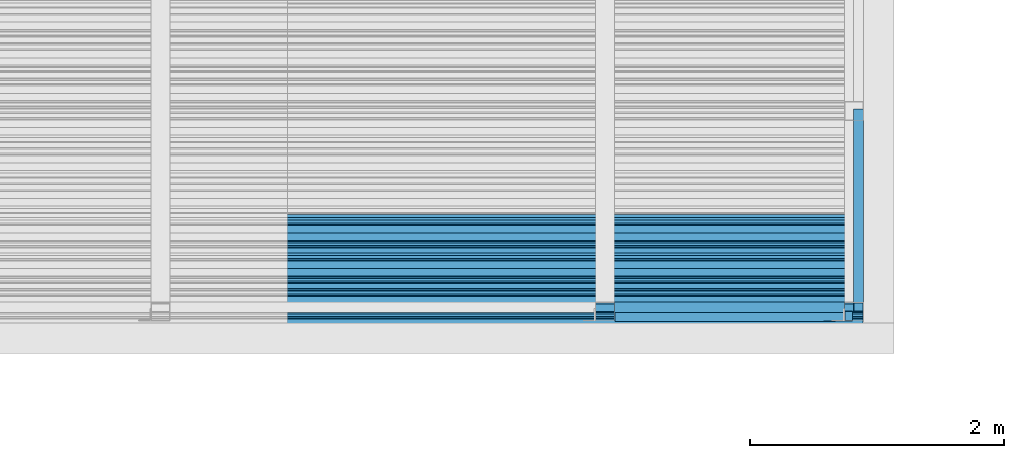
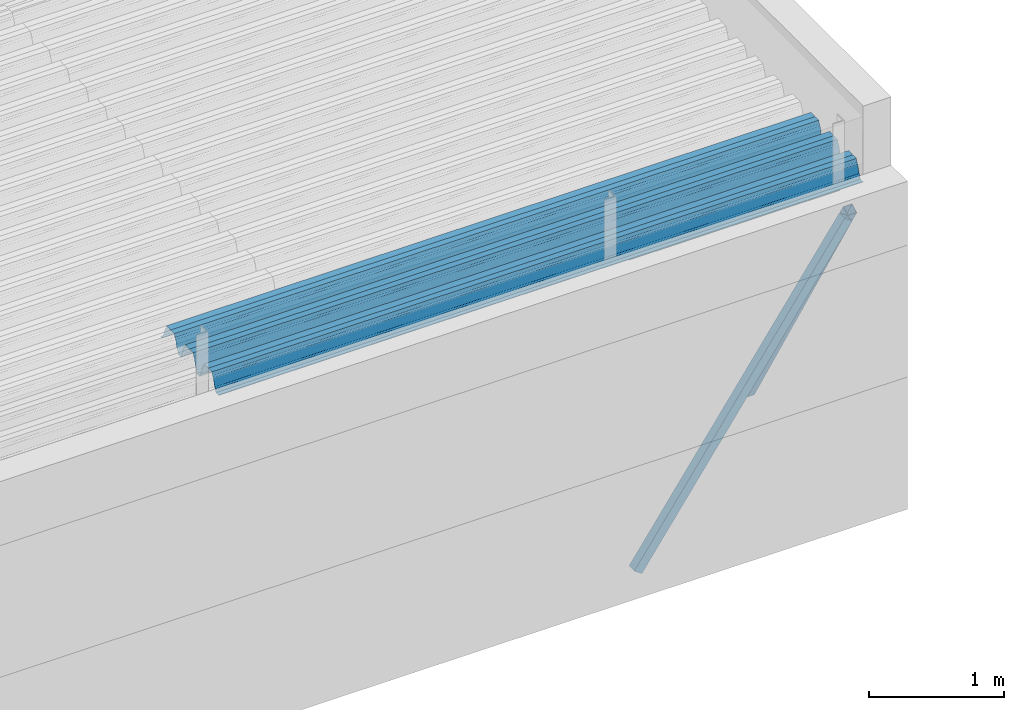
# One storey, part 21 of 153: 2 beams, 2 members, 4 elements without a shape of their own.
"""IFC2X3 building model written with IfcOpenShell, lengths in millimetres."""

from ifc_helpers import new_model, si_unit, frame, origin_with_axes, place, context, subcontext, project, spatial, faceted_brep, material, type_object, element, aggregate, save


model = new_model("IFC2X3")

# Units and contexts
model_context = context("Model", 3, precision=1e-05, world=origin_with_axes())
body_context = subcontext(model_context, "Body", "Model", "MODEL_VIEW")
ifc_project = project(units=[si_unit("LENGTHUNIT", "METRE", prefix="MILLI"), si_unit("AREAUNIT", "SQUARE_METRE"), si_unit("VOLUMEUNIT", "CUBIC_METRE"), si_unit("MASSUNIT", "GRAM", prefix="KILO"), si_unit("TIMEUNIT", "SECOND"), si_unit("PLANEANGLEUNIT", "RADIAN"), si_unit("SOLIDANGLEUNIT", "STERADIAN"), si_unit("THERMODYNAMICTEMPERATUREUNIT", "DEGREE_CELSIUS"), si_unit("LUMINOUSINTENSITYUNIT", "LUMEN")], contexts=[model_context])

# Site, building, storey
site_placement = place(None, origin_with_axes())
site = spatial("IfcSite", under=ifc_project, at=site_placement, CompositionType="ELEMENT")
building_placement = place(site_placement, origin_with_axes())
building = spatial("IfcBuilding", under=site, at=building_placement, CompositionType="ELEMENT")
storey_placement = place(building_placement, origin_with_axes())
storey = spatial("IfcBuildingStorey", under=building, at=storey_placement, Name="8", CompositionType="ELEMENT", Elevation=0.0)

# Assembly, beam
assembly_1_placement = place(storey_placement, origin_with_axes())
assembly_1 = element("IfcElementAssembly", 1, at=assembly_1_placement, inside=storey, Name="Steel Assembly", AssemblyPlace="NOTDEFINED", PredefinedType="RIGID_FRAME")
ifc_material = material(Name="STEEL/S355J2")
beam_type_1 = type_object("IfcBeamType", Name="80X80X4", PredefinedType="NOTDEFINED")
beam_1_placement = place(assembly_1_placement, frame((19827.0, 15090.0, 105625.0), z_axis=(0.0, 0.0, 1.0), x_axis=(1.0, 0.0, 0.0)))
beam_1 = element("IfcBeam", 2, at=beam_1_placement, type_object=beam_type_1, material=ifc_material, ObjectType="80X80X4", context=body_context, shape_type="Brep", body=[
    faceted_brep([(0.0, 36.0, -36.0), (0.0, -36.0, -36.0), (1810.0, -36.0, -36.0), (1810.0, 36.0, -36.0), (0.0, -36.0, 36.0), (1810.0, -36.0, 36.0), (0.0, 36.0, 36.0), (1810.0, 36.0, 36.0), (0.0, 40.0, -40.0), (0.0, 40.0, 40.0), (1810.0, 40.0, 40.0), (1810.0, 40.0, -40.0), (0.0, -40.0, 40.0), (1810.0, -40.0, 40.0), (0.0, -40.0, -40.0), (1810.0, -40.0, -40.0)], [[[0, 1, 2, 3]], [[1, 4, 5, 2]], [[4, 6, 7, 5]], [[6, 0, 3, 7]], [[8, 9, 10, 11]], [[9, 12, 13, 10]], [[12, 14, 15, 13]], [[14, 8, 11, 15]], [[13, 15, 11, 10], [5, 7, 3, 2]], [[14, 12, 9, 8], [6, 4, 1, 0]]]),
])
aggregate(assembly_1, [beam_1])

# Assembly, member
assembly_2_placement = place(storey_placement, origin_with_axes())
assembly_2 = element("IfcElementAssembly", 3, at=assembly_2_placement, inside=storey, Name="Steel Assembly", AssemblyPlace="NOTDEFINED", PredefinedType="RIGID_FRAME")
member_type = type_object("IfcMemberType", Name="80X80X4", PredefinedType="NOTDEFINED")
member_1_placement = place(assembly_2_placement, frame((21669.6844786879, 15019.8392286357, 105354.763247238), z_axis=(-0.817779656255445, 0.000577574000181237, 0.57553114617977), x_axis=(-0.575531427868873, -0.000984128999775929, -0.81777906981368)))
member_1 = element("IfcMember", 4, at=member_1_placement, type_object=member_type, material=ifc_material, ObjectType="80X80X4", context=body_context, shape_type="Brep", body=[
    faceted_brep([(0.0, 36.0, -36.0), (0.0, -36.0, -36.0), (3140.00228448592, -36.0000000000018, -35.9999999999927), (3140.00228448591, 35.9999999999982, -35.9999999999854), (0.0, -36.0, 36.0), (3140.00228452422, -36.0, 36.0000000000146), (0.0, 36.0, 36.0), (3140.00228452422, 36.0, 36.0000000000073), (0.0, 40.0, -40.0), (0.0, 40.0, 40.0), (3140.00228452636, 39.9999999999982, 40.0000000000073), (3140.00228448378, 39.9999999999964, -40.0), (0.0, -40.0, 40.0), (3140.00228452634, -40.0000000000018, 40.0000000000146), (0.0, -40.0, -40.0), (3140.00228448377, -40.0, -39.9999999999927)], [[[0, 1, 2, 3]], [[1, 4, 5, 2]], [[4, 6, 7, 5]], [[6, 0, 3, 7]], [[8, 9, 10, 11]], [[9, 12, 13, 10]], [[12, 14, 15, 13]], [[14, 8, 11, 15]], [[13, 15, 11, 10], [5, 7, 3, 2]], [[14, 12, 9, 8], [6, 4, 1, 0]]]),
])
aggregate(assembly_2, [member_1])

assembly_3_placement = place(storey_placement, origin_with_axes())
assembly_3 = element("IfcElementAssembly", 5, at=assembly_3_placement, inside=storey, Name="Steel Assembly", AssemblyPlace="NOTDEFINED", PredefinedType="RIGID_FRAME")
member_2_placement = place(assembly_3_placement, frame((21746.9120316846, 15091.8625281528, 105348.311116968), z_axis=(-5.07909999900242e-05, 0.860635157805855, 0.509222075885134), x_axis=(-3.00520000078842e-05, 0.509222075133064, -0.860635159224891)))
member_2 = element("IfcMember", 6, at=member_2_placement, type_object=member_type, material=ifc_material, ObjectType="80X80X4", context=body_context, shape_type="Brep", body=[
    faceted_brep([(0.0, 36.0, -36.0), (0.0, -36.0, -36.0), (2994.82303511504, -36.0, -35.9999999999854), (2994.82303511504, 36.0, -35.9999999999709), (0.0, -36.0, 36.0), (2994.82303510378, -36.0, 36.0000000000146), (0.0, 36.0, 36.0), (2994.82303510378, 36.0, 36.0000000000146), (0.0, 40.0, -40.0), (0.0, 40.0, 40.0), (2994.82303510315, 40.0, 40.0000000000146), (2994.82303511568, 40.0, -39.9999999999709), (0.0, -40.0, 40.0), (2994.82303510315, -40.0, 40.0000000000146), (0.0, -40.0, -40.0), (2994.82303511568, -40.0, -39.9999999999854)], [[[0, 1, 2, 3]], [[1, 4, 5, 2]], [[4, 6, 7, 5]], [[6, 0, 3, 7]], [[8, 9, 10, 11]], [[9, 12, 13, 10]], [[12, 14, 15, 13]], [[14, 8, 11, 15]], [[13, 15, 11, 10], [5, 7, 3, 2]], [[14, 12, 9, 8], [6, 4, 1, 0]]]),
])
aggregate(assembly_3, [member_2])

# Assembly, beam
assembly_4_placement = place(storey_placement, origin_with_axes())
assembly_4 = element("IfcElementAssembly", 7, at=assembly_4_placement, inside=storey, Name="Steel Assembly", AssemblyPlace="NOTDEFINED", PredefinedType="RIGID_FRAME")
beam_type_2 = type_object("IfcBeamType", Name="W", PredefinedType="NOTDEFINED")
beam_2_placement = place(assembly_4_placement, frame((21782.0, 15385.2090542547, 105749.900488243), z_axis=(0.0, -0.0124990270013869, 0.999921884110963), x_axis=(-1.0, 3.00000001838171e-08, 0.0)))
beam_2 = element("IfcBeam", 8, at=beam_2_placement, type_object=beam_type_2, material=ifc_material, ObjectType="W", context=body_context, shape_type="Brep", body=[
    faceted_brep([(0.0, -412.839996337891, -77.0100021362159), (0.0, -409.160003662109, -77.0100021362014), (5530.0, -409.160003662109, -77.0100021362014), (5530.0, -412.839996337891, -77.0100021362159), (0.0, -408.070007324222, -73.4800033569045), (5530.0, -408.070007324222, -73.4800033569045), (0.0, -400.339996337894, -48.0600013732619), (5530.0, -400.339996337894, -48.0600013732619), (0.0, -399.459991455082, -46.5600013732619), (5530.0, -399.459991455082, -46.5600013732619), (0.0, -390.329986572269, -36.5499992370314), (5530.0, -390.329986572269, -36.5499992370314), (0.0, -389.19000244141, -34.6300010680861), (5530.0, -389.19000244141, -34.6300010680861), (0.0, -367.820007324222, 35.3400001526024), (5530.0, -367.820007324222, 35.3400001526024), (0.0, -366.989990234379, 36.8499984741502), (5530.0, -366.989990234379, 36.8499984741502), (0.0, -357.809997558597, 46.8600006103807), (5530.0, -357.809997558597, 46.8600006103807), (0.0, -356.720001220707, 48.7700004577782), (5530.0, -356.720001220707, 48.7700004577782), (0.0, -349.309997558594, 73.1500015258935), (5530.0, -349.309997558594, 73.1500015258935), (0.0, -347.850006103516, 75.2300033569481), (5530.0, -347.850006103516, 75.2300033569481), (0.0, -345.470001220707, 76.010002136245), (5530.0, -345.470001220707, 76.010002136245), (0.0, -305.480010986332, 76.010002136245), (5530.0, -305.480010986332, 76.010002136245), (0.0, -304.279998779301, 75.8000030517578), (5530.0, -304.279998779301, 75.8000030517578), (0.0, -291.679992675785, 71.6999969482567), (5530.0, -291.679992675785, 71.6999969482567), (0.0, -290.179992675789, 71.2300033569481), (5530.0, -290.179992675789, 71.2300033569481), (0.0, -288.720001220707, 71.6999969482567), (5530.0, -288.720001220707, 71.6999969482567), (0.0, -276.119995117191, 75.8000030517869), (5530.0, -276.119995117191, 75.8000030517869), (0.0, -274.929992675785, 76.010002136245), (5530.0, -274.929992675785, 76.010002136245), (0.0, -234.94000244141, 76.010002136245), (5530.0, -234.94000244141, 76.010002136245), (0.0, -232.550003051758, 75.2300033569627), (5530.0, -232.550003051758, 75.2300033569627), (0.0, -231.100006103519, 73.1500015258935), (5530.0, -231.100006103519, 73.1500015258935), (0.0, -223.679992675785, 48.7700004577782), (5530.0, -223.679992675785, 48.7700004577782), (0.0, -222.589996337894, 46.8600006103661), (5530.0, -222.589996337894, 46.8600006103661), (0.0, -213.410003662113, 36.8499984741502), (5530.0, -213.410003662113, 36.8499984741502), (0.0, -212.529998779301, 35.3400001526024), (5530.0, -212.529998779301, 35.3400001526024), (0.0, -191.160003662109, -34.6300010681007), (5530.0, -191.160003662109, -34.6300010681007), (0.0, -190.070007324222, -36.5499992370605), (5530.0, -190.070007324222, -36.5499992370605), (0.0, -180.940002441406, -46.560001373291), (5530.0, -180.940002441406, -46.560001373291), (0.0, -180.059997558597, -48.0600013732619), (5530.0, -180.059997558597, -48.0600013732619), (0.0, -172.330001831055, -73.480003356919), (5530.0, -172.330001831055, -73.480003356919), (0.0, -171.240005493168, -77.0100021362159), (5530.0, -171.240005493168, -77.0100021362159), (0.0, -129.330001831062, -77.0100021362014), (5530.0, -129.330001831062, -77.0100021362014), (0.0, -128.300003051761, -73.480003356919), (5530.0, -128.300003051761, -73.480003356919), (0.0, -120.51999664307, -48.0600013732765), (5530.0, -120.51999664307, -48.0600013732765), (0.0, -119.629997253418, -46.5600013732765), (5530.0, -119.629997253418, -46.5600013732765), (0.0, -110.500000000004, -36.5499992370314), (5530.0, -110.500000000004, -36.5499992370314), (0.0, -109.419998168949, -34.6300010680861), (5530.0, -109.419998168949, -34.6300010680861), (0.0, -88.0500030517615, 35.3400001526024), (5530.0, -88.0500030517615, 35.3400001526024), (0.0, -87.160003662113, 36.8499984741356), (5530.0, -87.160003662113, 36.8499984741356), (0.0, -78.0400009155273, 46.8600006103807), (5530.0, -78.0400009155273, 46.8600006103807), (0.0, -76.8899993896557, 48.7700004577782), (5530.0, -76.8899993896557, 48.7700004577782), (0.0, -69.4800033569336, 73.1500015258935), (5530.0, -69.4800033569336, 73.1500015258935), (0.0, -68.0299987793042, 75.2300033569336), (5530.0, -68.0299987793042, 75.2300033569336), (0.0, -65.6399993896521, 76.010002136245), (5530.0, -65.6399993896521, 76.010002136245), (0.0, -25.6499996185375, 76.0100021362596), (5530.0, -25.6499996185375, 76.0100021362596), (0.0, -24.5100002288891, 75.8000030517724), (5530.0, -24.5100002288891, 75.8000030517724), (0.0, -11.8500003814697, 71.6999969482567), (5530.0, -11.8500003814697, 71.6999969482567), (0.0, -10.3999996185339, 71.2300033569481), (5530.0, -10.3999996185339, 71.2300033569481), (0.0, -8.89999961853391, 71.6999969482567), (5530.0, -8.89999961853391, 71.6999969482567), (0.0, 3.71000003814333, 75.8000030517724), (5530.0, 3.71000003814333, 75.8000030517724), (0.0, 4.90000009536379, 76.0100021362596), (5530.0, 4.90000009536379, 76.0100021362596), (0.0, 44.8899993896484, 76.010002136245), (5530.0, 44.8899993896484, 76.010002136245), (0.0, 47.2799987792932, 75.2300033569481), (5530.0, 47.2799987792932, 75.2300033569481), (0.0, 48.6800003051721, 73.1500015258935), (5530.0, 48.6800003051721, 73.1500015258935), (0.0, 56.1500015258753, 48.7700004577782), (5530.0, 56.1500015258753, 48.7700004577782), (0.0, 57.2400016784632, 46.8600006103807), (5530.0, 57.2400016784632, 46.8600006103807), (0.0, 66.3700027465784, 36.8499984741211), (5530.0, 66.3700027465784, 36.8499984741211), (0.0, 67.2499999999964, 35.3400001526024), (5530.0, 67.2499999999964, 35.3400001526024), (0.0, 88.6200027465748, -34.6300010681007), (5530.0, 88.6200027465748, -34.6300010681007), (0.0, 89.709999084469, -36.549999237046), (5530.0, 89.709999084469, -36.549999237046), (0.0, 98.8899993896412, -46.5600013732765), (5530.0, 98.8899993896412, -46.5600013732765), (0.0, 99.7699966430628, -48.0600013732765), (5530.0, 99.7699966430628, -48.0600013732765), (0.0, 107.499999999996, -73.4800033569336), (5530.0, 107.499999999996, -73.4800033569336), (0.0, 108.589996337887, -77.0100021362014), (5530.0, 108.589996337887, -77.0100021362014), (0.0, 112.269996643063, -77.0100021362159), (5530.0, 112.269996643063, -77.0100021362159), (0.0, 146.759994506836, -77.0100021362159), (5530.0, 146.759994506836, -77.0100021362159), (0.0, 150.440002441403, -77.0100021362159), (5530.0, 150.440002441403, -77.0100021362159), (0.0, 151.529998779297, -73.480003356919), (5530.0, 151.529998779297, -73.480003356919), (0.0, 159.30999755859, -48.0600013732765), (5530.0, 159.30999755859, -48.0600013732765), (0.0, 160.190002441406, -46.5600013732619), (5530.0, 160.190002441406, -46.5600013732619), (0.0, 169.320007324215, -36.549999237046), (5530.0, 169.320007324215, -36.549999237046), (0.0, 170.410003662106, -34.6300010680861), (5530.0, 170.410003662106, -34.6300010680861), (0.0, 191.779998779293, 35.3400001526024), (5530.0, 191.779998779293, 35.3400001526024), (0.0, 192.660003662109, 36.8499984741502), (5530.0, 192.660003662109, 36.8499984741502), (0.0, 201.789993286129, 46.8600006103661), (5530.0, 201.789993286129, 46.8600006103661), (0.0, 202.880004882809, 48.7700004577637), (5530.0, 202.880004882809, 48.7700004577637), (0.0, 210.350006103512, 73.150001525908), (5530.0, 210.350006103512, 73.150001525908), (0.0, 211.800003051754, 75.2300033569481), (5530.0, 211.800003051754, 75.2300033569481), (0.0, 214.190002441406, 76.010002136245), (5530.0, 214.190002441406, 76.010002136245), (0.0, 254.179992675778, 76.010002136245), (5530.0, 254.179992675778, 76.010002136245), (0.0, 255.320007324215, 75.8000030517869), (5530.0, 255.320007324215, 75.8000030517869), (0.0, 267.980010986324, 71.6999969482713), (5530.0, 267.980010986324, 71.6999969482713), (0.0, 269.429992675778, 71.2300033569481), (5530.0, 269.429992675778, 71.2300033569481), (0.0, 270.880004882809, 71.6999969482567), (5530.0, 270.880004882809, 71.6999969482567), (0.0, 283.540008544918, 75.8000030517869), (5530.0, 283.540008544918, 75.8000030517869), (0.0, 284.679992675778, 76.010002136245), (5530.0, 284.679992675778, 76.010002136245), (0.0, 324.670013427731, 76.010002136245), (5530.0, 324.670013427731, 76.010002136245), (0.0, 327.049987792969, 75.2300033569627), (5530.0, 327.049987792969, 75.2300033569627), (0.0, 328.510009765625, 73.1500015258789), (5530.0, 328.510009765625, 73.1500015258789), (0.0, 335.980010986324, 48.7700004577782), (5530.0, 335.980010986324, 48.7700004577782), (0.0, 337.05999755859, 46.8600006103661), (5530.0, 337.05999755859, 46.8600006103661), (0.0, 346.190002441399, 36.8499984741356), (5530.0, 346.190002441399, 36.8499984741356), (0.0, 347.079986572266, 35.3400001526024), (5530.0, 347.079986572266, 35.3400001526024), (0.0, 368.450012207028, -34.6300010680861), (5530.0, 368.450012207028, -34.6300010680861), (0.0, 369.529998779293, -36.5499992370314), (5530.0, 369.529998779293, -36.5499992370314), (0.0, 378.660003662106, -46.5600013732619), (5530.0, 378.660003662106, -46.5600013732619), (0.0, 379.540008544918, -48.0600013732619), (5530.0, 379.540008544918, -48.0600013732619), (0.0, 387.329986572262, -73.480003356919), (5530.0, 387.329986572262, -73.480003356919), (0.0, 388.410003662109, -77.0100021362159), (5530.0, 388.410003662109, -77.0100021362159), (0.0, 392.100006103512, -77.0100021362159), (5530.0, 392.100006103512, -77.0100021362159), (0.0, 426.589996337887, -77.0100021362159), (5530.0, 426.589996337887, -77.0100021362159), (0.0, 430.269989013668, -77.0100021362159), (5530.0, 430.269989013668, -77.0100021362159), (0.0, 431.359985351559, -73.4800033569045), (5530.0, 431.359985351559, -73.4800033569045), (0.0, 433.179992675778, -67.5699996948097), (5530.0, 433.179992675778, -67.5699996948097), (0.0, 432.220001220699, -67.2699966430373), (5530.0, 432.220001220699, -67.2699966430373), (0.0, 430.410003662106, -73.1800003051612), (5530.0, 430.410003662106, -73.1800003051612), (0.0, 429.529998779293, -76.0100021362159), (5530.0, 429.529998779293, -76.0100021362159), (0.0, 426.589996337891, -76.0100021362159), (5530.0, 426.589996337891, -76.0100021362159), (0.0, 392.100006103512, -76.0100021362159), (5530.0, 392.100006103512, -76.0100021362159), (0.0, 389.149993896481, -76.0100021362014), (5530.0, 389.149993896481, -76.0100021362014), (0.0, 388.279998779293, -73.1800003051467), (5530.0, 388.279998779293, -73.1800003051467), (0.0, 380.470001220699, -47.659999847383), (5530.0, 380.470001220699, -47.659999847383), (0.0, 379.470001220699, -45.9599990844436), (5530.0, 379.470001220699, -45.9599990844436), (0.0, 370.350006103512, -35.9599990844581), (5530.0, 370.350006103512, -35.9599990844581), (0.0, 369.369995117184, -34.2299995422218), (5530.0, 369.369995117184, -34.2299995422218), (0.0, 347.999999999996, 35.7500000000146), (5530.0, 347.999999999996, 35.7500000000146), (0.0, 346.999999999996, 37.4399986267235), (5530.0, 346.999999999996, 37.4399986267235), (0.0, 337.880004882809, 47.450000762954), (5530.0, 337.880004882809, 47.450000762954), (0.0, 336.899993896481, 49.1699981689453), (5530.0, 336.899993896481, 49.1699981689453), (0.0, 329.420013427731, 73.5999984741356), (5530.0, 329.420013427731, 73.5999984741356), (0.0, 327.679992675781, 76.0699996948533), (5530.0, 327.679992675781, 76.0699996948533), (0.0, 324.829986572262, 77.010002136245), (5530.0, 324.829986572262, 77.010002136245), (0.0, 284.589996337887, 77.010002136245), (5530.0, 284.589996337887, 77.010002136245), (0.0, 283.290008544922, 76.769996643081), (5530.0, 283.290008544922, 76.769996643081), (0.0, 270.570007324215, 72.6500015258935), (5530.0, 270.570007324215, 72.6500015258935), (0.0, 269.429992675781, 72.2799987793114), (5530.0, 269.429992675781, 72.2799987793114), (0.0, 268.279998779293, 72.650001525908), (5530.0, 268.279998779293, 72.650001525908), (0.0, 255.570007324219, 76.769996643081), (5530.0, 255.570007324219, 76.769996643081), (0.0, 254.270004272461, 77.0100021362596), (5530.0, 254.270004272461, 77.0100021362596), (0.0, 214.029998779293, 77.0100021362596), (5530.0, 214.029998779293, 77.0100021362596), (0.0, 211.179992675781, 76.0699996948388), (5530.0, 211.179992675781, 76.0699996948388), (0.0, 209.440002441403, 73.5999984741356), (5530.0, 209.440002441403, 73.5999984741356), (0.0, 201.960006713864, 49.1699981689599), (5530.0, 201.960006713864, 49.1699981689599), (0.0, 200.979995727532, 47.450000762954), (5530.0, 200.979995727532, 47.450000762954), (0.0, 191.850006103508, 37.4399986267235), (5530.0, 191.850006103508, 37.4399986267235), (0.0, 190.860000610352, 35.7500000000146), (5530.0, 190.860000610352, 35.7500000000146), (0.0, 169.49000549316, -34.2299995422218), (5530.0, 169.49000549316, -34.2299995422218), (0.0, 168.509994506832, -35.9599990844581), (5530.0, 168.509994506832, -35.9599990844581), (0.0, 159.380004882805, -45.9599990844436), (5530.0, 159.380004882805, -45.9599990844436), (0.0, 158.389999389645, -47.6599998473976), (5530.0, 158.389999389645, -47.6599998473976), (0.0, 150.580001831051, -73.1800003051612), (5530.0, 150.580001831051, -73.1800003051612), (0.0, 149.710006713864, -76.0100021362159), (5530.0, 149.710006713864, -76.0100021362159), (0.0, 146.759994506836, -76.0100021362159), (5530.0, 146.759994506836, -76.0100021362159), (0.0, 112.269996643063, -76.0100021362159), (5530.0, 112.269996643063, -76.0100021362159), (0.0, 109.319999694821, -76.0100021362159), (5530.0, 109.319999694821, -76.0100021362159), (0.0, 108.449996948239, -73.1900024413917), (5530.0, 108.449996948239, -73.1900024413917), (0.0, 100.690002441406, -47.659999847383), (5530.0, 100.690002441406, -47.659999847383), (0.0, 99.6999969482386, -45.9599990844581), (5530.0, 99.6999969482386, -45.9599990844581), (0.0, 90.5199966430664, -35.9599990844581), (5530.0, 90.5199966430664, -35.9599990844581), (0.0, 89.5400009155273, -34.2299995422218), (5530.0, 89.5400009155273, -34.2299995422218), (0.0, 68.1699981689417, 35.7500000000146), (5530.0, 68.1699981689417, 35.7500000000146), (0.0, 67.1699981689417, 37.4399986267235), (5530.0, 67.1699981689417, 37.4399986267235), (0.0, 58.0499992370569, 47.4500007629686), (5530.0, 58.0499992370569, 47.4500007629686), (0.0, 57.0699996948206, 49.1699981689599), (5530.0, 57.0699996948206, 49.1699981689599), (0.0, 49.5900001525843, 73.5899963379052), (5530.0, 49.5900001525843, 73.5899963379052), (0.0, 47.9099998474085, 76.0699996948388), (5530.0, 47.9099998474085, 76.0699996948388), (0.0, 45.0499992370569, 77.010002136245), (5530.0, 45.0499992370569, 77.010002136245), (0.0, 4.82000017165774, 77.010002136245), (5530.0, 4.82000017165774, 77.010002136245), (0.0, 3.47000002860659, 76.7699966430955), (5530.0, 3.47000002860659, 76.7699966430955), (0.0, -9.19999980926514, 72.6500015258935), (5530.0, -9.19999980926514, 72.6500015258935), (0.0, -10.3900003433264, 72.2799987792969), (5530.0, -10.3900003433264, 72.2799987792969), (0.0, -11.5399999618567, 72.6500015258935), (5530.0, -11.5399999618567, 72.6500015258935), (0.0, -24.2600002288855, 76.769996643081), (5530.0, -24.2600002288855, 76.769996643081), (0.0, -25.559999465946, 77.0100021362596), (5530.0, -25.559999465946, 77.0100021362596), (0.0, -65.8000030517615, 77.0100021362596), (5530.0, -65.8000030517615, 77.0100021362596), (0.0, -68.6500015258862, 76.0699996948533), (5530.0, -68.6500015258862, 76.0699996948533), (0.0, -70.3899993896521, 73.5999984741356), (5530.0, -70.3899993896521, 73.5999984741356), (0.0, -77.8199996948242, 49.1800003051903), (5530.0, -77.8199996948242, 49.1800003051903), (0.0, -78.8399963378943, 47.450000762954), (5530.0, -78.8399963378943, 47.450000762954), (0.0, -87.9700012207031, 37.4399986267235), (5530.0, -87.9700012207031, 37.4399986267235), (0.0, -88.9700012207068, 35.7500000000146), (5530.0, -88.9700012207068, 35.7500000000146), (0.0, -110.339996337894, -34.2299995422218), (5530.0, -110.339996337894, -34.2299995422218), (0.0, -111.319999694828, -35.9599990844581), (5530.0, -111.319999694828, -35.9599990844581), (0.0, -120.440002441406, -45.9599990844436), (5530.0, -120.440002441406, -45.9599990844436), (0.0, -121.44000244141, -47.6599998473976), (5530.0, -121.44000244141, -47.6599998473976), (0.0, -129.250000000004, -73.1900024413771), (5530.0, -129.250000000004, -73.1900024413771), (0.0, -130.080001831062, -76.0100021362159), (5530.0, -130.080001831062, -76.0100021362159), (0.0, -170.5, -76.0100021362014), (5530.0, -170.5, -76.0100021362014), (0.0, -171.380004882816, -73.1900024413917), (5530.0, -171.380004882816, -73.1900024413917), (0.0, -179.139999389652, -47.6599998473976), (5530.0, -179.139999389652, -47.6599998473976), (0.0, -180.130004882816, -45.9599990844581), (5530.0, -180.130004882816, -45.9599990844581), (0.0, -189.259994506836, -35.9599990844581), (5530.0, -189.259994506836, -35.9599990844581), (0.0, -190.240005493168, -34.2299995422218), (5530.0, -190.240005493168, -34.2299995422218), (0.0, -211.610000610355, 35.7500000000146), (5530.0, -211.610000610355, 35.7500000000146), (0.0, -212.600006103519, 37.4399986267381), (5530.0, -212.600006103519, 37.4399986267381), (0.0, -221.779998779301, 47.450000762954), (5530.0, -221.779998779301, 47.450000762954), (0.0, -222.75999450684, 49.1699981689599), (5530.0, -222.75999450684, 49.1699981689599), (0.0, -230.190002441406, 73.5999984741356), (5530.0, -230.190002441406, 73.5999984741356), (0.0, -231.919998168945, 76.0699996948388), (5530.0, -231.919998168945, 76.0699996948388), (0.0, -234.779998779301, 77.010002136245), (5530.0, -234.779998779301, 77.010002136245), (0.0, -275.010009765629, 77.010002136245), (5530.0, -275.010009765629, 77.010002136245), (0.0, -276.359985351563, 76.769996643081), (5530.0, -276.359985351563, 76.769996643081), (0.0, -289.029998779297, 72.6500015258789), (5530.0, -289.029998779297, 72.6500015258789), (0.0, -290.179992675785, 72.2799987793114), (5530.0, -290.179992675785, 72.2799987793114), (0.0, -291.380004882816, 72.650001525908), (5530.0, -291.380004882816, 72.650001525908), (0.0, -304.040008544926, 76.769996643081), (5530.0, -304.040008544926, 76.769996643081), (0.0, -305.390014648441, 77.010002136245), (5530.0, -305.390014648441, 77.010002136245), (0.0, -345.63000488282, 77.0100021362596), (5530.0, -345.63000488282, 77.0100021362596), (0.0, -348.480010986332, 76.0699996948388), (5530.0, -348.480010986332, 76.0699996948388), (0.0, -350.220001220707, 73.5999984741356), (5530.0, -350.220001220707, 73.5999984741356), (0.0, -357.649993896492, 49.1699981689599), (5530.0, -357.649993896492, 49.1699981689599), (0.0, -358.63000488282, 47.450000762954), (5530.0, -358.63000488282, 47.450000762954), (0.0, -367.809997558594, 37.4300003051903), (5530.0, -367.809997558594, 37.4300003051903), (0.0, -368.750000000004, 35.7299995422654), (5530.0, -368.750000000004, 35.7299995422654), (0.0, -390.109985351566, -34.2200012207031), (5530.0, -390.109985351566, -34.2200012207031), (0.0, -391.140014648441, -35.9500007629249), (5530.0, -391.140014648441, -35.9500007629249), (0.0, -400.269989013676, -45.9599990844436), (5530.0, -400.269989013676, -45.9599990844436), (0.0, -401.269989013672, -47.6599998473976), (5530.0, -401.269989013672, -47.6599998473976), (0.0, -409.029998779297, -73.1900024413917), (5530.0, -409.029998779297, -73.1900024413917), (0.0, -409.899993896488, -76.0100021362159), (5530.0, -409.899993896488, -76.0100021362159), (0.0, -412.839996337891, -76.0100021362159), (5530.0, -412.839996337891, -76.0100021362159), (0.0, -433.179992675785, -76.0100021362159), (5530.0, -433.179992675785, -76.0100021362159), (0.0, -433.179992675785, -77.0100021362159), (5530.0, -433.179992675785, -77.0100021362159)], [[[0, 1, 2, 3]], [[1, 4, 5, 2]], [[4, 6, 7, 5]], [[6, 8, 9, 7]], [[8, 10, 11, 9]], [[10, 12, 13, 11]], [[12, 14, 15, 13]], [[14, 16, 17, 15]], [[16, 18, 19, 17]], [[18, 20, 21, 19]], [[20, 22, 23, 21]], [[22, 24, 25, 23]], [[24, 26, 27, 25]], [[26, 28, 29, 27]], [[28, 30, 31, 29]], [[30, 32, 33, 31]], [[32, 34, 35, 33]], [[34, 36, 37, 35]], [[36, 38, 39, 37]], [[38, 40, 41, 39]], [[40, 42, 43, 41]], [[42, 44, 45, 43]], [[44, 46, 47, 45]], [[46, 48, 49, 47]], [[48, 50, 51, 49]], [[50, 52, 53, 51]], [[52, 54, 55, 53]], [[54, 56, 57, 55]], [[56, 58, 59, 57]], [[58, 60, 61, 59]], [[60, 62, 63, 61]], [[62, 64, 65, 63]], [[64, 66, 67, 65]], [[66, 68, 69, 67]], [[68, 70, 71, 69]], [[70, 72, 73, 71]], [[72, 74, 75, 73]], [[74, 76, 77, 75]], [[76, 78, 79, 77]], [[78, 80, 81, 79]], [[80, 82, 83, 81]], [[82, 84, 85, 83]], [[84, 86, 87, 85]], [[86, 88, 89, 87]], [[88, 90, 91, 89]], [[90, 92, 93, 91]], [[92, 94, 95, 93]], [[94, 96, 97, 95]], [[96, 98, 99, 97]], [[98, 100, 101, 99]], [[100, 102, 103, 101]], [[102, 104, 105, 103]], [[104, 106, 107, 105]], [[106, 108, 109, 107]], [[108, 110, 111, 109]], [[110, 112, 113, 111]], [[112, 114, 115, 113]], [[114, 116, 117, 115]], [[116, 118, 119, 117]], [[118, 120, 121, 119]], [[120, 122, 123, 121]], [[122, 124, 125, 123]], [[124, 126, 127, 125]], [[126, 128, 129, 127]], [[128, 130, 131, 129]], [[130, 132, 133, 131]], [[132, 134, 135, 133]], [[134, 136, 137, 135]], [[136, 138, 139, 137]], [[138, 140, 141, 139]], [[140, 142, 143, 141]], [[142, 144, 145, 143]], [[144, 146, 147, 145]], [[146, 148, 149, 147]], [[148, 150, 151, 149]], [[150, 152, 153, 151]], [[152, 154, 155, 153]], [[154, 156, 157, 155]], [[156, 158, 159, 157]], [[158, 160, 161, 159]], [[160, 162, 163, 161]], [[162, 164, 165, 163]], [[164, 166, 167, 165]], [[166, 168, 169, 167]], [[168, 170, 171, 169]], [[170, 172, 173, 171]], [[172, 174, 175, 173]], [[174, 176, 177, 175]], [[176, 178, 179, 177]], [[178, 180, 181, 179]], [[180, 182, 183, 181]], [[182, 184, 185, 183]], [[184, 186, 187, 185]], [[186, 188, 189, 187]], [[188, 190, 191, 189]], [[190, 192, 193, 191]], [[192, 194, 195, 193]], [[194, 196, 197, 195]], [[196, 198, 199, 197]], [[198, 200, 201, 199]], [[200, 202, 203, 201]], [[202, 204, 205, 203]], [[204, 206, 207, 205]], [[206, 208, 209, 207]], [[208, 210, 211, 209]], [[210, 212, 213, 211]], [[212, 214, 215, 213]], [[214, 216, 217, 215]], [[216, 218, 219, 217]], [[218, 220, 221, 219]], [[220, 222, 223, 221]], [[222, 224, 225, 223]], [[224, 226, 227, 225]], [[226, 228, 229, 227]], [[228, 230, 231, 229]], [[230, 232, 233, 231]], [[232, 234, 235, 233]], [[234, 236, 237, 235]], [[236, 238, 239, 237]], [[238, 240, 241, 239]], [[240, 242, 243, 241]], [[242, 244, 245, 243]], [[244, 246, 247, 245]], [[246, 248, 249, 247]], [[248, 250, 251, 249]], [[250, 252, 253, 251]], [[252, 254, 255, 253]], [[254, 256, 257, 255]], [[256, 258, 259, 257]], [[258, 260, 261, 259]], [[260, 262, 263, 261]], [[262, 264, 265, 263]], [[264, 266, 267, 265]], [[266, 268, 269, 267]], [[268, 270, 271, 269]], [[270, 272, 273, 271]], [[272, 274, 275, 273]], [[274, 276, 277, 275]], [[276, 278, 279, 277]], [[278, 280, 281, 279]], [[280, 282, 283, 281]], [[282, 284, 285, 283]], [[284, 286, 287, 285]], [[286, 288, 289, 287]], [[288, 290, 291, 289]], [[290, 292, 293, 291]], [[292, 294, 295, 293]], [[294, 296, 297, 295]], [[296, 298, 299, 297]], [[298, 300, 301, 299]], [[300, 302, 303, 301]], [[302, 304, 305, 303]], [[304, 306, 307, 305]], [[306, 308, 309, 307]], [[308, 310, 311, 309]], [[310, 312, 313, 311]], [[312, 314, 315, 313]], [[314, 316, 317, 315]], [[316, 318, 319, 317]], [[318, 320, 321, 319]], [[320, 322, 323, 321]], [[322, 324, 325, 323]], [[324, 326, 327, 325]], [[326, 328, 329, 327]], [[328, 330, 331, 329]], [[330, 332, 333, 331]], [[332, 334, 335, 333]], [[334, 336, 337, 335]], [[336, 338, 339, 337]], [[338, 340, 341, 339]], [[340, 342, 343, 341]], [[342, 344, 345, 343]], [[344, 346, 347, 345]], [[346, 348, 349, 347]], [[348, 350, 351, 349]], [[350, 352, 353, 351]], [[352, 354, 355, 353]], [[354, 356, 357, 355]], [[356, 358, 359, 357]], [[358, 360, 361, 359]], [[360, 362, 363, 361]], [[362, 364, 365, 363]], [[364, 366, 367, 365]], [[366, 368, 369, 367]], [[368, 370, 371, 369]], [[370, 372, 373, 371]], [[372, 374, 375, 373]], [[374, 376, 377, 375]], [[376, 378, 379, 377]], [[378, 380, 381, 379]], [[380, 382, 383, 381]], [[382, 384, 385, 383]], [[384, 386, 387, 385]], [[386, 388, 389, 387]], [[388, 390, 391, 389]], [[390, 392, 393, 391]], [[392, 394, 395, 393]], [[394, 396, 397, 395]], [[396, 398, 399, 397]], [[398, 400, 401, 399]], [[400, 402, 403, 401]], [[402, 404, 405, 403]], [[404, 406, 407, 405]], [[406, 408, 409, 407]], [[408, 410, 411, 409]], [[410, 412, 413, 411]], [[412, 414, 415, 413]], [[414, 416, 417, 415]], [[416, 418, 419, 417]], [[418, 420, 421, 419]], [[420, 422, 423, 421]], [[422, 424, 425, 423]], [[424, 426, 427, 425]], [[426, 428, 429, 427]], [[428, 430, 431, 429]], [[430, 0, 3, 431]], [[5, 7, 9, 11, 13, 15, 17, 19, 21, 23, 25, 27, 29, 31, 33, 35, 37, 39, 41, 43, 45, 47, 49, 51, 53, 55, 57, 59, 61, 63, 65, 67, 69, 71, 73, 75, 77, 79, 81, 83, 85, 87, 89, 91, 93, 95, 97, 99, 101, 103, 105, 107, 109, 111, 113, 115, 117, 119, 121, 123, 125, 127, 129, 131, 133, 135, 137, 139, 141, 143, 145, 147, 149, 151, 153, 155, 157, 159, 161, 163, 165, 167, 169, 171, 173, 175, 177, 179, 181, 183, 185, 187, 189, 191, 193, 195, 197, 199, 201, 203, 205, 207, 209, 211, 213, 215, 217, 219, 221, 223, 225, 227, 229, 231, 233, 235, 237, 239, 241, 243, 245, 247, 249, 251, 253, 255, 257, 259, 261, 263, 265, 267, 269, 271, 273, 275, 277, 279, 281, 283, 285, 287, 289, 291, 293, 295, 297, 299, 301, 303, 305, 307, 309, 311, 313, 315, 317, 319, 321, 323, 325, 327, 329, 331, 333, 335, 337, 339, 341, 343, 345, 347, 349, 351, 353, 355, 357, 359, 361, 363, 365, 367, 369, 371, 373, 375, 377, 379, 381, 383, 385, 387, 389, 391, 393, 395, 397, 399, 401, 403, 405, 407, 409, 411, 413, 415, 417, 419, 421, 423, 425, 427, 429, 431, 3, 2]], [[430, 428, 426, 424, 422, 420, 418, 416, 414, 412, 410, 408, 406, 404, 402, 400, 398, 396, 394, 392, 390, 388, 386, 384, 382, 380, 378, 376, 374, 372, 370, 368, 366, 364, 362, 360, 358, 356, 354, 352, 350, 348, 346, 344, 342, 340, 338, 336, 334, 332, 330, 328, 326, 324, 322, 320, 318, 316, 314, 312, 310, 308, 306, 304, 302, 300, 298, 296, 294, 292, 290, 288, 286, 284, 282, 280, 278, 276, 274, 272, 270, 268, 266, 264, 262, 260, 258, 256, 254, 252, 250, 248, 246, 244, 242, 240, 238, 236, 234, 232, 230, 228, 226, 224, 222, 220, 218, 216, 214, 212, 210, 208, 206, 204, 202, 200, 198, 196, 194, 192, 190, 188, 186, 184, 182, 180, 178, 176, 174, 172, 170, 168, 166, 164, 162, 160, 158, 156, 154, 152, 150, 148, 146, 144, 142, 140, 138, 136, 134, 132, 130, 128, 126, 124, 122, 120, 118, 116, 114, 112, 110, 108, 106, 104, 102, 100, 98, 96, 94, 92, 90, 88, 86, 84, 82, 80, 78, 76, 74, 72, 70, 68, 66, 64, 62, 60, 58, 56, 54, 52, 50, 48, 46, 44, 42, 40, 38, 36, 34, 32, 30, 28, 26, 24, 22, 20, 18, 16, 14, 12, 10, 8, 6, 4, 1, 0]]]),
])
aggregate(assembly_4, [beam_2])

save(model, "model.ifc")
